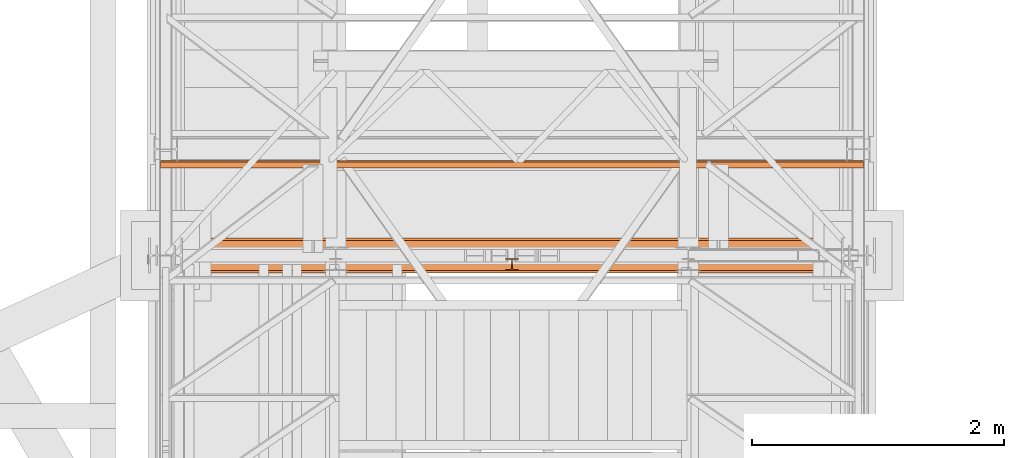
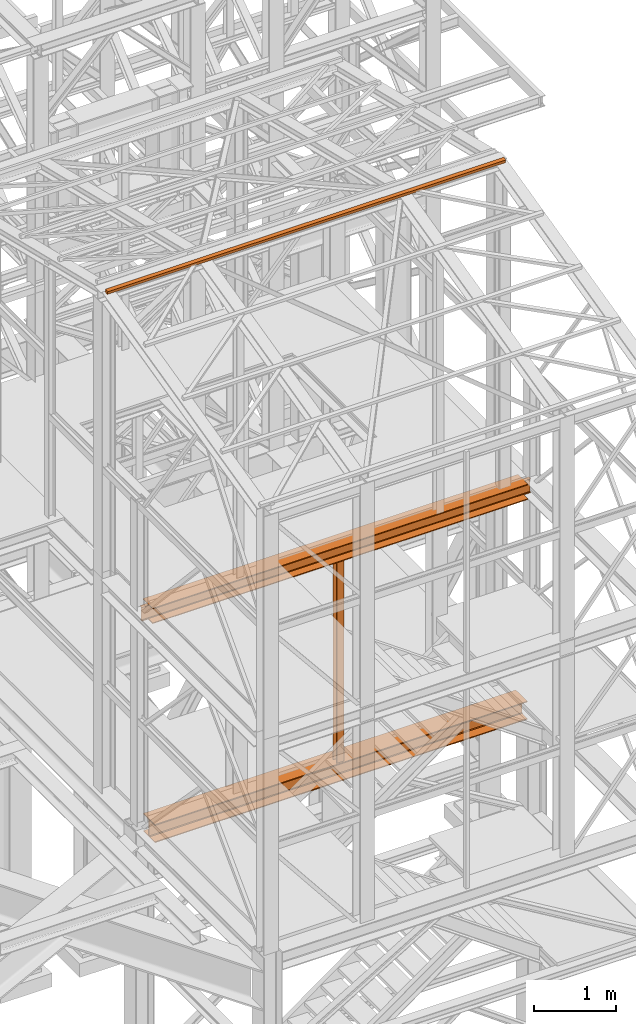
# One storey, part 55 of 208: 4 proxies.
"""IFC2X3 building model written with IfcOpenShell, lengths in millimetres."""

from ifc_helpers import new_model, entity, si_unit, converted_unit, frame, origin, origin_with_axes, place, context, subcontext, project, spatial, faceted_brep, element, save


model = new_model("IFC2X3")

# Units and contexts
model_context = context("Model", 3, precision=1e-05, world=origin())
plan_context = context("Plan", 3, precision=1e-05, world=origin())
body_context = subcontext(model_context, "Body", "Model", "MODEL_VIEW")
ifc_project = project(units=[si_unit("LENGTHUNIT", "METRE", prefix="MILLI"), converted_unit("PLANEANGLEUNIT", "DEGREE", entity("IfcPlaneAngleMeasure", 0.0174532925199433), si_unit("PLANEANGLEUNIT", "RADIAN"), dimensions=[0, 0, 0, 0, 0, 0, 0]), si_unit("AREAUNIT", "SQUARE_METRE"), si_unit("VOLUMEUNIT", "CUBIC_METRE")], contexts=[model_context, plan_context])

# Building, storey
building_placement = place(None, origin())
building = spatial("IfcBuilding", under=ifc_project, at=building_placement, CompositionType="COMPLEX")
storey_placement = place(building_placement, origin_with_axes())
storey = spatial("IfcBuildingStorey", under=building, at=storey_placement, Name="Geschoss", CompositionType="ELEMENT")

# Proxies
proxy_1_placement = place(storey_placement, frame((1223.004970257197, -22182.57439508626, 8254.989997913835), z_axis=(0.0, 0.0, 1.0), x_axis=(1.0, 0.0, 0.0)))
element("IfcBuildingElementProxy", 1, at=proxy_1_placement, inside=storey, context=body_context, shape_type="Brep", body=[
    faceted_brep([(5450.509996542936, 144.7600064969047, 218.0100022053684), (5450.509996542936, 133.8915605267866, 215.8347008919682), (5450.509996542936, 125.9353108873947, 207.8784493899311), (5450.509996542936, 123.7600049173816, 197.0100043511357), (5450.509996542936, 123.7600049173816, 33.00999982118628), (5450.509996542936, 125.9353108873947, 22.14155478239081), (5450.509996542936, 133.8915605267866, 14.18530328035376), (5450.509996542936, 144.7600064969047, 12.0100019669535), (5450.509996542936, 95.26000303983528, 12.0100019669535), (5450.509996542936, 106.1284490099533, 14.18530328035376), (5450.509996542936, 114.0846986493452, 22.14155478239081), (5450.509996542936, 116.2600046193584, 33.00999982118628), (5450.509996542936, 116.2600046193584, 197.0100043511357), (5450.509996542936, 114.0846986493452, 207.8784493899311), (5450.509996542936, 106.1284490099533, 215.8347008919682), (5450.509996542936, 95.26000303983528, 218.0100022053684), (5355.259993503099, 0.00999999999839929, 230.0100041723217), (95.26000303983801, 0.00999999999839929, 230.0100041723217), (95.26000303983801, 240.0100095367416, 230.0100041723217), (5355.2599935031, 240.0100095367416, 230.0100041723217), (5355.2599935031, 240.0100095367416, 230.0100041723217), (95.26000303983801, 240.0100095367416, 230.0100041723217), (95.26000303983619, 240.0100095367416, 218.0100022053684), (5355.2599935031, 240.0100095367416, 218.0100022053703), (5355.2599935031, 240.0100095367416, 218.0100022053703), (95.26000303983619, 240.0100095367416, 218.0100022053684), (95.26000303983801, 144.7600064969047, 218.0100022053684), (5355.259993503099, 144.7600064969047, 218.0100022053684), (5450.509996542936, 133.8915605267866, 215.8347008919682), (5450.509996542936, 144.7600064969047, 218.0100022053684), (5355.259993503099, 144.7600064969047, 218.0100022053684), (95.26000303983801, 144.7600064969047, 218.0100022053684), (0.01000000000021828, 144.7600064969047, 218.0100022053684), (0.01000000000021828, 133.8915605267866, 215.8347008919682), (5450.509996542936, 125.9353108873947, 207.8784493899311), (5450.509996542936, 133.8915605267866, 215.8347008919682), (0.01000000000021828, 133.8915605267866, 215.8347008919682), (0.01000000000021828, 125.9353108873947, 207.8784493899311), (5450.509996542936, 123.7600049173816, 197.0100043511357), (5450.509996542936, 125.9353108873947, 207.8784493899311), (0.01000000000021828, 125.9353108873947, 207.8784493899311), (0.01000000000021828, 123.7600049173816, 197.0100043511357), (5450.509996542936, 123.7600049173816, 33.00999982118628), (5450.509996542936, 123.7600049173816, 197.0100043511357), (0.01000000000021828, 123.7600049173816, 197.0100043511357), (0.01000000000021828, 123.7600049173816, 33.00999982118628), (5450.509996542936, 125.9353108873947, 22.14155478239081), (5450.509996542936, 123.7600049173816, 33.00999982118628), (0.01000000000021828, 123.7600049173816, 33.00999982118628), (0.01000000000021828, 125.9353108873947, 22.14155478239081), (5450.509996542936, 133.8915605267866, 14.18530328035376), (5450.509996542936, 125.9353108873947, 22.14155478239081), (0.01000000000021828, 125.9353108873947, 22.14155478239081), (0.01000000000021828, 133.8915605267866, 14.18530328035376), (5450.509996542936, 144.7600064969047, 12.0100019669535), (5450.509996542936, 133.8915605267866, 14.18530328035376), (0.01000000000021828, 133.8915605267866, 14.18530328035376), (0.01000000000021828, 144.7600064969047, 12.0100019669535), (95.26000303983619, 144.7600064969047, 12.0100019669535), (5355.2599935031, 144.7600064969047, 12.01000196695168), (5355.2599935031, 144.7600064969047, 12.01000196695168), (95.26000303983619, 144.7600064969047, 12.0100019669535), (95.26000303983801, 240.0100095367416, 12.0100019669535), (5355.2599935031, 240.0100095367416, 12.01000196695168), (5355.2599935031, 240.0100095367416, 12.01000196695168), (95.26000303983801, 240.0100095367416, 12.0100019669535), (95.26000303983619, 240.0100095367416, 0.01000000000021828), (5355.2599935031, 240.0100095367416, 0.01000000000021828), (5355.2599935031, 240.0100095367416, 0.01000000000021828), (95.26000303983619, 240.0100095367416, 0.01000000000021828), (95.26000303983801, 0.00999999999839929, 0.01000000000021828), (5355.259993503099, 0.00999999999839929, 0.01000000000021828), (5355.259993503099, 0.00999999999839929, 0.01000000000021828), (95.26000303983801, 0.00999999999839929, 0.01000000000021828), (95.26000303983801, 0.00999999999839929, 12.0100019669535), (5355.259993503099, 0.00999999999839929, 12.0100019669535), (5355.259993503099, 0.00999999999839929, 12.0100019669535), (95.26000303983801, 0.00999999999839929, 12.0100019669535), (95.26000303983801, 95.26000303983528, 12.0100019669535), (5355.259993503099, 95.26000303983528, 12.0100019669535), (5450.509996542936, 106.1284490099533, 14.18530328035376), (5450.509996542936, 95.26000303983528, 12.0100019669535), (5355.259993503099, 95.26000303983528, 12.0100019669535), (95.26000303983801, 95.26000303983528, 12.0100019669535), (0.01000000000021828, 95.26000303983528, 12.0100019669535), (0.01000000000021828, 106.1284490099533, 14.18530328035376), (5450.509996542936, 114.0846986493452, 22.14155478239081), (5450.509996542936, 106.1284490099533, 14.18530328035376), (0.01000000000021828, 106.1284490099533, 14.18530328035376), (0.01000000000021828, 114.0846986493452, 22.14155478239081), (5450.509996542936, 116.2600046193584, 33.00999982118628), (5450.509996542936, 114.0846986493452, 22.14155478239081), (0.01000000000021828, 114.0846986493452, 22.14155478239081), (0.01000000000021828, 116.2600046193584, 33.00999982118628), (5450.509996542936, 116.2600046193584, 197.0100043511357), (5450.509996542936, 116.2600046193584, 33.00999982118628), (0.01000000000021828, 116.2600046193584, 33.00999982118628), (0.01000000000021828, 116.2600046193584, 197.0100043511357), (5450.509996542936, 114.0846986493452, 207.8784493899311), (5450.509996542936, 116.2600046193584, 197.0100043511357), (0.01000000000021828, 116.2600046193584, 197.0100043511357), (0.01000000000021828, 114.0846986493452, 207.8784493899311), (5450.509996542936, 106.1284490099533, 215.8347008919682), (5450.509996542936, 114.0846986493452, 207.8784493899311), (0.01000000000021828, 114.0846986493452, 207.8784493899311), (0.01000000000021828, 106.1284490099533, 215.8347008919682), (5450.509996542936, 95.26000303983528, 218.0100022053684), (5450.509996542936, 106.1284490099533, 215.8347008919682), (0.01000000000021828, 106.1284490099533, 215.8347008919682), (0.01000000000021828, 95.26000303983528, 218.0100022053684), (95.26000303983619, 95.26000303983528, 218.0100022053684), (5355.259993503099, 95.26000303983528, 218.0100022053684), (5355.259993503099, 95.26000303983528, 218.0100022053684), (95.26000303983619, 95.26000303983528, 218.0100022053684), (95.26000303983801, 0.00999999999839929, 218.0100022053684), (5355.259993503099, 0.00999999999839929, 218.0100022053684), (5355.259993503099, 0.00999999999839929, 218.0100022053684), (95.26000303983801, 0.00999999999839929, 218.0100022053684), (95.26000303983801, 0.00999999999839929, 230.0100041723217), (5355.259993503099, 0.00999999999839929, 230.0100041723217), (0.01000000000021828, 95.26000303983528, 218.0100022053684), (0.01000000000021828, 106.1284490099533, 215.8347008919682), (0.01000000000021828, 114.0846986493452, 207.8784493899311), (0.01000000000021828, 116.2600046193584, 197.0100043511357), (0.01000000000021828, 116.2600046193584, 33.00999982118628), (0.01000000000021828, 114.0846986493452, 22.14155478239081), (0.01000000000021828, 106.1284490099533, 14.18530328035376), (0.01000000000021828, 95.26000303983528, 12.0100019669535), (0.01000000000021828, 144.7600064969047, 12.0100019669535), (0.01000000000021828, 133.8915605267866, 14.18530328035376), (0.01000000000021828, 125.9353108873947, 22.14155478239081), (0.01000000000021828, 123.7600049173816, 33.00999982118628), (0.01000000000021828, 123.7600049173816, 197.0100043511357), (0.01000000000021828, 125.9353108873947, 207.8784493899311), (0.01000000000021828, 133.8915605267866, 215.8347008919682), (0.01000000000021828, 144.7600064969047, 218.0100022053684), (5355.259993503099, 0.00999999999839929, 0.01000000000021828), (5355.259993503099, 0.00999999999839929, 12.0100019669535), (5355.259993503099, 95.26000303983528, 12.0100019669535), (5355.2599935031, 144.7600064969047, 12.01000196695168), (5355.2599935031, 240.0100095367416, 12.01000196695168), (5355.2599935031, 240.0100095367416, 0.01000000000021828), (5355.259993503099, 95.26000303983528, 12.0100019669535), (5450.509996542936, 95.26000303983528, 12.0100019669535), (5450.509996542936, 144.7600064969047, 12.0100019669535), (5355.2599935031, 144.7600064969047, 12.01000196695168), (5450.509996542936, 95.26000303983528, 218.0100022053684), (5355.259993503099, 95.26000303983528, 218.0100022053684), (5355.259993503099, 144.7600064969047, 218.0100022053684), (5450.509996542936, 144.7600064969047, 218.0100022053684), (5355.259993503099, 0.00999999999839929, 218.0100022053684), (5355.259993503099, 0.00999999999839929, 230.0100041723217), (5355.2599935031, 240.0100095367416, 230.0100041723217), (5355.2599935031, 240.0100095367416, 218.0100022053703), (5355.259993503099, 144.7600064969047, 218.0100022053684), (5355.259993503099, 95.26000303983528, 218.0100022053684), (95.26000303983801, 0.00999999999839929, 230.0100041723217), (95.26000303983801, 0.00999999999839929, 218.0100022053684), (95.26000303983619, 95.26000303983528, 218.0100022053684), (95.26000303983801, 144.7600064969047, 218.0100022053684), (95.26000303983619, 240.0100095367416, 218.0100022053684), (95.26000303983801, 240.0100095367416, 230.0100041723217), (95.26000303983619, 95.26000303983528, 218.0100022053684), (0.01000000000021828, 95.26000303983528, 218.0100022053684), (0.01000000000021828, 144.7600064969047, 218.0100022053684), (95.26000303983801, 144.7600064969047, 218.0100022053684), (0.01000000000021828, 95.26000303983528, 12.0100019669535), (95.26000303983801, 95.26000303983528, 12.0100019669535), (95.26000303983619, 144.7600064969047, 12.0100019669535), (0.01000000000021828, 144.7600064969047, 12.0100019669535), (95.26000303983801, 0.00999999999839929, 12.0100019669535), (95.26000303983801, 0.00999999999839929, 0.01000000000021828), (95.26000303983619, 240.0100095367416, 0.01000000000021828), (95.26000303983801, 240.0100095367416, 12.0100019669535), (95.26000303983619, 144.7600064969047, 12.0100019669535), (95.26000303983801, 95.26000303983528, 12.0100019669535)], [[[0, 1, 2, 3, 4, 5, 6, 7, 8, 9, 10, 11, 12, 13, 14, 15]], [[16, 17, 18, 19]], [[20, 21, 22, 23]], [[24, 25, 26, 27]], [[28, 29, 30, 31, 32, 33]], [[34, 35, 36, 37]], [[38, 39, 40, 41]], [[42, 43, 44, 45]], [[46, 47, 48, 49]], [[50, 51, 52, 53]], [[54, 55, 56, 57, 58, 59]], [[60, 61, 62, 63]], [[64, 65, 66, 67]], [[68, 69, 70, 71]], [[72, 73, 74, 75]], [[76, 77, 78, 79]], [[80, 81, 82, 83, 84, 85]], [[86, 87, 88, 89]], [[90, 91, 92, 93]], [[94, 95, 96, 97]], [[98, 99, 100, 101]], [[102, 103, 104, 105]], [[106, 107, 108, 109, 110, 111]], [[112, 113, 114, 115]], [[116, 117, 118, 119]], [[120, 121, 122, 123, 124, 125, 126, 127, 128, 129, 130, 131, 132, 133, 134, 135]], [[136, 137, 138, 139, 140, 141]], [[142, 143, 144, 145]], [[146, 147, 148, 149]], [[150, 151, 152, 153, 154, 155]], [[156, 157, 158, 159, 160, 161]], [[162, 163, 164, 165]], [[166, 167, 168, 169]], [[170, 171, 172, 173, 174, 175]]], orient=[[False], [False], [False], [False], [False], [False], [False], [False], [False], [False], [False], [False], [False], [False], [False], [False], [False], [False], [False], [False], [False], [False], [False], [False], [False], [False], [False], [False], [False], [False], [False], [False], [False], [False]]),
])
proxy_2_placement = place(storey_placement, frame((1157.254971121462, -21366.51929152406, 12689.02228571494), z_axis=(0.0, 0.0, 1.0), x_axis=(1.0, 0.0, 0.0)))
element("IfcBuildingElementProxy", 2, at=proxy_2_placement, inside=storey, context=body_context, shape_type="Brep", body=[
    faceted_brep([(5582.010002264974, 48.59909357395372, 60.39315927079588), (5582.010002264974, 60.39315927079224, 11.80406569683873), (5582.010002264974, 11.80406569683328, 0.01000000000021828), (5582.010002264974, 0.00999999999839929, 48.59909357395736), (0.01000000000021828, 0.00999999999839929, 48.59909357395736), (0.01000000000021828, 11.80406569683328, 0.01000000000021828), (0.01000000000021828, 60.39315927079224, 11.80406569683873), (0.01000000000021828, 48.59909357395372, 60.39315927079588), (5582.010002264974, 0.00999999999839929, 48.59909357395736), (0.01000000000021828, 0.00999999999839929, 48.59909357395736), (0.01000000000021828, 48.59909357395372, 60.39315927079588), (5582.010002264974, 48.59909357395372, 60.39315927079588), (5582.010002264974, 11.80406569683328, 0.01000000000021828), (0.01000000000021828, 11.80406569683328, 0.01000000000021828), (0.01000000000021828, 0.00999999999839929, 48.59909357395736), (5582.010002264974, 0.00999999999839929, 48.59909357395736), (5582.010002264974, 60.39315927079224, 11.80406569683873), (0.01000000000021828, 60.39315927079224, 11.80406569683873), (0.01000000000021828, 11.80406569683328, 0.01000000000021828), (5582.010002264974, 11.80406569683328, 0.01000000000021828), (5582.010002264974, 48.59909357395372, 60.39315927079588), (0.01000000000021828, 48.59909357395372, 60.39315927079588), (0.01000000000021828, 60.39315927079224, 11.80406569683873), (5582.010002264974, 60.39315927079224, 11.80406569683873)], [[[0, 1, 2, 3]], [[4, 5, 6, 7]], [[8, 9, 10, 11]], [[12, 13, 14, 15]], [[16, 17, 18, 19]], [[20, 21, 22, 23]]], orient=[[False], [False], [False], [False], [False], [False]]),
])
proxy_3_placement = place(storey_placement, frame((1333.164824146425, -22202.57439091394, 5014.98999463558), z_axis=(0.0, 0.0, 1.0), x_axis=(1.0, 0.0, 0.0)))
element("IfcBuildingElementProxy", 3, at=proxy_3_placement, inside=storey, context=body_context, shape_type="Brep", body=[
    faceted_brep([(5225.100143786193, 0.01000000000203727, 270.0100107288363), (5.100144978286153, 0.01000000000203727, 270.0100107288354), (5.100144978286153, 280.0100011920986, 270.0100107288354), (5225.100143786193, 280.0100011920949, 270.0100107288363), (5225.100143786193, 280.0100011920949, 270.0100107288363), (5.100144978286153, 280.0100011920986, 270.0100107288354), (5.100144978286153, 280.0100011920986, 257.0100141859048), (5225.100143786193, 280.0100011920949, 257.0100141859057), (5225.100143786193, 280.0100011920949, 257.0100141859057), (5.100144978286153, 280.0100011920986, 257.0100141859048), (5.100144978286153, 168.0100014603195, 257.0100141859048), (5225.100143786193, 168.0100014603158, 257.0100141859057), (5230.100139017824, 168.0100014603158, 257.0100141859057), (5225.100143786193, 168.0100014603158, 257.0100141859057), (5.100144978286153, 168.0100014603195, 257.0100141859048), (0.01000000000021828, 168.0100014603195, 257.0100141859048), (0.01000000000021828, 155.5889206177053, 254.5239491558068), (5230.100139017824, 155.5889206177017, 254.5239491558077), (5230.100139017824, 155.5889206177017, 254.5239491558077), (0.01000000000021828, 155.5889206177053, 254.5239491558068), (0.01000000000112777, 146.4960648848173, 245.4310892319672), (5230.100139017824, 146.4960648848137, 245.4310892319681), (5230.100139017824, 146.4960648848137, 245.4310892319681), (0.01000000000112777, 146.4960648848173, 245.4310892319672), (0.01000000000021828, 144.0100007860419, 233.0100102519982), (5230.100139017824, 144.0100007860383, 233.0100102519991), (5230.100139017824, 144.0100007860383, 233.0100102519991), (0.01000000000021828, 144.0100007860419, 233.0100102519982), (0.01000000000112777, 144.0100007860419, 37.01000047683738), (5230.100139017824, 144.0100007860383, 37.01000047683738), (5230.100139017824, 144.0100007860383, 37.01000047683738), (0.01000000000112777, 144.0100007860419, 37.01000047683738), (0.01000000000112777, 146.4960648848173, 24.58892149686835), (5230.100139017824, 146.4960648848137, 24.58892149686835), (5230.100139017824, 146.4960648848137, 24.58892149686835), (0.01000000000112777, 146.4960648848173, 24.58892149686835), (0.01000000000112777, 155.5889206177053, 15.49606157302878), (5230.100139017824, 155.5889206177017, 15.49606157302878), (5230.100139017824, 155.5889206177017, 15.49606157302878), (0.01000000000112777, 155.5889206177053, 15.49606157302878), (0.01000000000021828, 168.0100014603195, 13.00999654293082), (5.100144978286153, 168.0100014603195, 13.00999654293082), (5225.100143786193, 168.0100014603158, 13.00999654293082), (5230.100139017824, 168.0100014603158, 13.00999654293082), (5225.100143786193, 168.0100014603158, 13.00999654293082), (5.100144978286153, 168.0100014603195, 13.00999654293082), (5.100144978286153, 280.0100011920986, 13.00999654293082), (5225.100143786193, 280.0100011920949, 13.00999654293082), (5225.100143786193, 280.0100011920949, 13.00999654293082), (5.100144978286153, 280.0100011920986, 13.00999654293082), (5.100144978286153, 280.0100011920986, 0.01000000000021828), (5225.100143786193, 280.0100011920949, 0.01000000000021828), (5225.100143786193, 280.0100011920949, 0.01000000000021828), (5.100144978286153, 280.0100011920986, 0.01000000000021828), (5.100144978286153, 0.01000000000203727, 0.009999999999308784), (5225.100143786193, 0.01000000000203727, 0.01000000000021828), (5225.100143786193, 0.01000000000203727, 0.01000000000021828), (5.100144978286153, 0.01000000000203727, 0.009999999999308784), (5.100144978286153, 0.01000000000203727, 13.00999654293082), (5225.100143786193, 0.01000000000203727, 13.00999654293082), (5225.100143786193, 0.01000000000203727, 13.00999654293082), (5.100144978286153, 0.01000000000203727, 13.00999654293082), (5.100144978286153, 112.0099997317848, 13.00999654293082), (5225.100143786193, 112.0099997317811, 13.00999654293082), (5230.100139017824, 112.0099997317811, 13.00999654293082), (5225.100143786193, 112.0099997317811, 13.00999654293082), (5.100144978286153, 112.0099997317848, 13.00999654293082), (0.01000000000112777, 112.0099997317848, 13.00999654293082), (0.01000000000112777, 124.431080574399, 15.49606157302878), (5230.100139017824, 124.4310805743953, 15.49606157302878), (5230.100139017824, 124.4310805743953, 15.49606157302878), (0.01000000000112777, 124.431080574399, 15.49606157302878), (0.01000000000112777, 133.5239363072869, 24.58892149686926), (5230.100139017824, 133.5239363072833, 24.58892149686835), (5230.100139017824, 133.5239363072833, 24.58892149686835), (0.01000000000112777, 133.5239363072869, 24.58892149686926), (0.01000000000112777, 136.0100004060623, 37.01000047683738), (5230.100139017824, 136.0100004060587, 37.01000047683738), (5230.100139017824, 136.0100004060587, 37.01000047683738), (0.01000000000112777, 136.0100004060623, 37.01000047683738), (0.01000000000112777, 136.0100004060623, 233.0100102519991), (5230.100139017824, 136.0100004060587, 233.0100102519991), (5230.100139017824, 136.0100004060587, 233.0100102519991), (0.01000000000112777, 136.0100004060623, 233.0100102519991), (0.01000000000021828, 133.5239363072869, 245.4310892319672), (5230.100139017824, 133.5239363072833, 245.4310892319681), (5230.100139017824, 133.5239363072833, 245.4310892319681), (0.01000000000021828, 133.5239363072869, 245.4310892319672), (0.01000000000021828, 124.431080574399, 254.5239491558068), (5230.100139017824, 124.4310805743953, 254.5239491558077), (5230.100139017824, 124.4310805743953, 254.5239491558077), (0.01000000000021828, 124.431080574399, 254.5239491558068), (0.01000000000112777, 112.0099997317848, 257.0100141859048), (5.100144978287062, 112.0099997317848, 257.0100141859048), (5225.100143786193, 112.0099997317811, 257.0100141859057), (5230.100139017824, 112.0099997317811, 257.0100141859057), (5225.100143786193, 112.0099997317811, 257.0100141859057), (5.100144978287062, 112.0099997317848, 257.0100141859048), (5.100144978286153, 0.01000000000203727, 257.0100141859048), (5225.100143786193, 0.01000000000203727, 257.0100141859057), (5225.100143786193, 0.01000000000203727, 257.0100141859057), (5.100144978286153, 0.01000000000203727, 257.0100141859048), (5.100144978286153, 0.01000000000203727, 270.0100107288354), (5225.100143786193, 0.01000000000203727, 270.0100107288363), (5225.100143786193, 280.0100011920949, 270.0100107288363), (5225.100143786193, 280.0100011920949, 257.0100141859057), (5225.100143786193, 168.0100014603158, 257.0100141859057), (5225.100143786193, 112.0099997317811, 257.0100141859057), (5225.100143786193, 0.01000000000203727, 257.0100141859057), (5225.100143786193, 0.01000000000203727, 270.0100107288363), (5225.100143786193, 168.0100014603158, 257.0100141859057), (5230.100139017824, 168.0100014603158, 257.0100141859057), (5230.100139017824, 112.0099997317811, 257.0100141859057), (5225.100143786193, 112.0099997317811, 257.0100141859057), (5230.100139017824, 168.0100014603158, 13.00999654293082), (5225.100143786193, 168.0100014603158, 13.00999654293082), (5225.100143786193, 112.0099997317811, 13.00999654293082), (5230.100139017824, 112.0099997317811, 13.00999654293082), (5225.100143786193, 280.0100011920949, 13.00999654293082), (5225.100143786193, 280.0100011920949, 0.01000000000021828), (5225.100143786193, 0.01000000000203727, 0.01000000000021828), (5225.100143786193, 0.01000000000203727, 13.00999654293082), (5225.100143786193, 112.0099997317811, 13.00999654293082), (5225.100143786193, 168.0100014603158, 13.00999654293082), (5.100144978286153, 280.0100011920986, 0.01000000000021828), (5.100144978286153, 280.0100011920986, 13.00999654293082), (5.100144978286153, 168.0100014603195, 13.00999654293082), (5.100144978286153, 112.0099997317848, 13.00999654293082), (5.100144978286153, 0.01000000000203727, 13.00999654293082), (5.100144978286153, 0.01000000000203727, 0.009999999999308784), (5.100144978286153, 168.0100014603195, 13.00999654293082), (0.01000000000021828, 168.0100014603195, 13.00999654293082), (0.01000000000112777, 112.0099997317848, 13.00999654293082), (5.100144978286153, 112.0099997317848, 13.00999654293082), (0.01000000000021828, 168.0100014603195, 257.0100141859048), (5.100144978286153, 168.0100014603195, 257.0100141859048), (5.100144978287062, 112.0099997317848, 257.0100141859048), (0.01000000000112777, 112.0099997317848, 257.0100141859048), (5.100144978286153, 280.0100011920986, 257.0100141859048), (5.100144978286153, 280.0100011920986, 270.0100107288354), (5.100144978286153, 0.01000000000203727, 270.0100107288354), (5.100144978286153, 0.01000000000203727, 257.0100141859048), (5.100144978287062, 112.0099997317848, 257.0100141859048), (5.100144978286153, 168.0100014603195, 257.0100141859048), (0.01000000000021828, 168.0100014603195, 257.0100141859048), (0.01000000000112777, 112.0099997317848, 257.0100141859048), (0.01000000000021828, 124.431080574399, 254.5239491558068), (0.01000000000021828, 133.5239363072869, 245.4310892319672), (0.01000000000112777, 136.0100004060623, 233.0100102519991), (0.01000000000112777, 136.0100004060623, 37.01000047683738), (0.01000000000112777, 133.5239363072869, 24.58892149686926), (0.01000000000112777, 124.431080574399, 15.49606157302878), (0.01000000000112777, 112.0099997317848, 13.00999654293082), (0.01000000000021828, 168.0100014603195, 13.00999654293082), (0.01000000000112777, 155.5889206177053, 15.49606157302878), (0.01000000000112777, 146.4960648848173, 24.58892149686835), (0.01000000000112777, 144.0100007860419, 37.01000047683738), (0.01000000000021828, 144.0100007860419, 233.0100102519982), (0.01000000000112777, 146.4960648848173, 245.4310892319672), (0.01000000000021828, 155.5889206177053, 254.5239491558068), (5230.100139017824, 155.5889206177017, 254.5239491558077), (5230.100139017824, 146.4960648848137, 245.4310892319681), (5230.100139017824, 144.0100007860383, 233.0100102519991), (5230.100139017824, 144.0100007860383, 37.01000047683738), (5230.100139017824, 146.4960648848137, 24.58892149686835), (5230.100139017824, 155.5889206177017, 15.49606157302878), (5230.100139017824, 168.0100014603158, 13.00999654293082), (5230.100139017824, 112.0099997317811, 13.00999654293082), (5230.100139017824, 124.4310805743953, 15.49606157302878), (5230.100139017824, 133.5239363072833, 24.58892149686835), (5230.100139017824, 136.0100004060587, 37.01000047683738), (5230.100139017824, 136.0100004060587, 233.0100102519991), (5230.100139017824, 133.5239363072833, 245.4310892319681), (5230.100139017824, 124.4310805743953, 254.5239491558077), (5230.100139017824, 112.0099997317811, 257.0100141859057), (5230.100139017824, 168.0100014603158, 257.0100141859057)], [[[0, 1, 2, 3]], [[4, 5, 6, 7]], [[8, 9, 10, 11]], [[12, 13, 14, 15, 16, 17]], [[18, 19, 20, 21]], [[22, 23, 24, 25]], [[26, 27, 28, 29]], [[30, 31, 32, 33]], [[34, 35, 36, 37]], [[38, 39, 40, 41, 42, 43]], [[44, 45, 46, 47]], [[48, 49, 50, 51]], [[52, 53, 54, 55]], [[56, 57, 58, 59]], [[60, 61, 62, 63]], [[64, 65, 66, 67, 68, 69]], [[70, 71, 72, 73]], [[74, 75, 76, 77]], [[78, 79, 80, 81]], [[82, 83, 84, 85]], [[86, 87, 88, 89]], [[90, 91, 92, 93, 94, 95]], [[96, 97, 98, 99]], [[100, 101, 102, 103]], [[104, 105, 106, 107, 108, 109]], [[110, 111, 112, 113]], [[114, 115, 116, 117]], [[118, 119, 120, 121, 122, 123]], [[124, 125, 126, 127, 128, 129]], [[130, 131, 132, 133]], [[134, 135, 136, 137]], [[138, 139, 140, 141, 142, 143]], [[144, 145, 146, 147, 148, 149, 150, 151, 152, 153, 154, 155, 156, 157, 158, 159]], [[160, 161, 162, 163, 164, 165, 166, 167, 168, 169, 170, 171, 172, 173, 174, 175]]], orient=[[False], [False], [False], [False], [False], [False], [False], [False], [False], [False], [False], [False], [False], [False], [False], [False], [False], [False], [False], [False], [False], [False], [False], [False], [False], [False], [False], [False], [False], [False], [False], [False], [False], [False]]),
])
proxy_4_placement = place(storey_placement, frame((3898.319663719516, -22182.57439508626, 5284.990005364416), z_axis=(0.0, 0.0, 1.0), x_axis=(1.0, 0.0, 0.0)))
element("IfcBuildingElementProxy", 4, at=proxy_4_placement, inside=storey, context=body_context, shape_type="Brep", body=[
    faceted_brep([(0.01000000000021828, 8.0099999999984, 0.01000000000021828), (0.01000000000021828, 0.00999999999839929, 0.01000000000021828), (100.0100000000002, 0.00999999999839929, 0.01000000000021828), (100.0100000000002, 8.0099999999984, 0.01000000000021828), (52.51000000000022, 8.0099999999984, 0.01000000000021828), (52.51000000000022, 88.0099999999984, 0.01000000000021828), (100.0100000000002, 88.0099999999984, 0.01000000000021828), (100.0100000000002, 96.0099999999984, 0.01000000000021828), (0.01000000000021828, 96.0099999999984, 0.01000000000021828), (0.01000000000021828, 88.0099999999984, 0.01000000000021828), (47.51000000000022, 88.0099999999984, 0.01000000000021828), (47.51000000000022, 8.0099999999984, 0.01000000000021828), (0.01000000000021828, 0.00999999999839929, 0.01000000000021828), (0.01000000000021828, 8.0099999999984, 0.01000000000021828), (0.01000000000203727, 8.0099999999984, 2970.00999254942), (0.01000000000203727, 0.00999999999839929, 2970.00999254942), (100.0100000000002, 0.00999999999839929, 0.01000000000021828), (0.01000000000021828, 0.00999999999839929, 0.01000000000021828), (0.01000000000203727, 0.00999999999839929, 2970.00999254942), (100.010000000002, 0.00999999999839929, 2970.00999254942), (100.0100000000002, 8.0099999999984, 0.01000000000021828), (100.0100000000002, 0.00999999999839929, 0.01000000000021828), (100.010000000002, 0.00999999999839929, 2970.00999254942), (100.010000000002, 8.0099999999984, 2970.00999254942), (52.51000000000022, 8.0099999999984, 0.01000000000021828), (100.0100000000002, 8.0099999999984, 0.01000000000021828), (100.010000000002, 8.0099999999984, 2970.00999254942), (52.51000000000204, 8.0099999999984, 2970.00999254942), (52.51000000000022, 88.0099999999984, 0.01000000000021828), (52.51000000000022, 8.0099999999984, 0.01000000000021828), (52.51000000000204, 8.0099999999984, 2970.00999254942), (52.51000000000204, 88.0099999999984, 2970.00999254942), (100.0100000000002, 88.0099999999984, 0.01000000000021828), (52.51000000000022, 88.0099999999984, 0.01000000000021828), (52.51000000000204, 88.0099999999984, 2970.00999254942), (100.010000000002, 88.0099999999984, 2970.00999254942), (100.0100000000002, 96.0099999999984, 0.01000000000021828), (100.0100000000002, 88.0099999999984, 0.01000000000021828), (100.010000000002, 88.0099999999984, 2970.00999254942), (100.010000000002, 96.0099999999984, 2970.00999254942), (0.01000000000021828, 96.0099999999984, 0.01000000000021828), (100.0100000000002, 96.0099999999984, 0.01000000000021828), (100.010000000002, 96.0099999999984, 2970.00999254942), (0.01000000000203727, 96.0099999999984, 2970.00999254942), (0.01000000000021828, 88.0099999999984, 0.01000000000021828), (0.01000000000021828, 96.0099999999984, 0.01000000000021828), (0.01000000000203727, 96.0099999999984, 2970.00999254942), (0.01000000000203727, 88.0099999999984, 2970.00999254942), (47.51000000000022, 88.0099999999984, 0.01000000000021828), (0.01000000000021828, 88.0099999999984, 0.01000000000021828), (0.01000000000203727, 88.0099999999984, 2970.00999254942), (47.51000000000204, 88.0099999999984, 2970.00999254942), (47.51000000000022, 8.0099999999984, 0.01000000000021828), (47.51000000000022, 88.0099999999984, 0.01000000000021828), (47.51000000000204, 88.0099999999984, 2970.00999254942), (47.51000000000204, 8.0099999999984, 2970.00999254942), (0.01000000000021828, 8.0099999999984, 0.01000000000021828), (47.51000000000022, 8.0099999999984, 0.01000000000021828), (47.51000000000204, 8.0099999999984, 2970.00999254942), (0.01000000000203727, 8.0099999999984, 2970.00999254942), (0.01000000000203727, 8.0099999999984, 2970.00999254942), (47.51000000000204, 8.0099999999984, 2970.00999254942), (47.51000000000204, 88.0099999999984, 2970.00999254942), (0.01000000000203727, 88.0099999999984, 2970.00999254942), (0.01000000000203727, 96.0099999999984, 2970.00999254942), (100.010000000002, 96.0099999999984, 2970.00999254942), (100.010000000002, 88.0099999999984, 2970.00999254942), (52.51000000000204, 88.0099999999984, 2970.00999254942), (52.51000000000204, 8.0099999999984, 2970.00999254942), (100.010000000002, 8.0099999999984, 2970.00999254942), (100.010000000002, 0.00999999999839929, 2970.00999254942), (0.01000000000203727, 0.00999999999839929, 2970.00999254942)], [[[0, 1, 2, 3, 4, 5, 6, 7, 8, 9, 10, 11]], [[12, 13, 14, 15]], [[16, 17, 18, 19]], [[20, 21, 22, 23]], [[24, 25, 26, 27]], [[28, 29, 30, 31]], [[32, 33, 34, 35]], [[36, 37, 38, 39]], [[40, 41, 42, 43]], [[44, 45, 46, 47]], [[48, 49, 50, 51]], [[52, 53, 54, 55]], [[56, 57, 58, 59]], [[60, 61, 62, 63, 64, 65, 66, 67, 68, 69, 70, 71]]], orient=[[False], [False], [False], [False], [False], [False], [False], [False], [False], [False], [False], [False], [False], [False]]),
])

save(model, "model.ifc")
